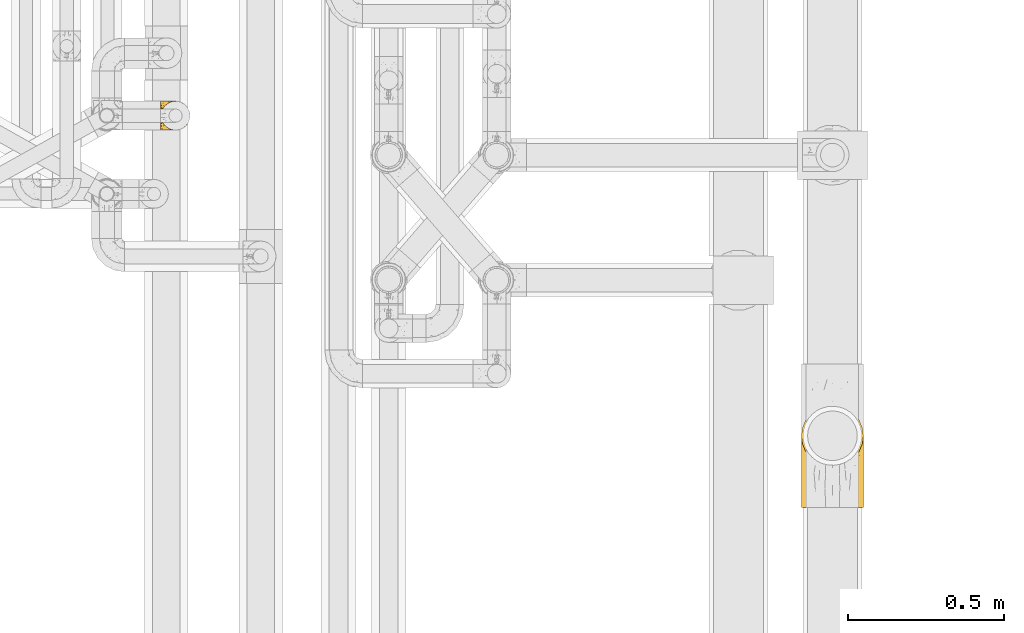
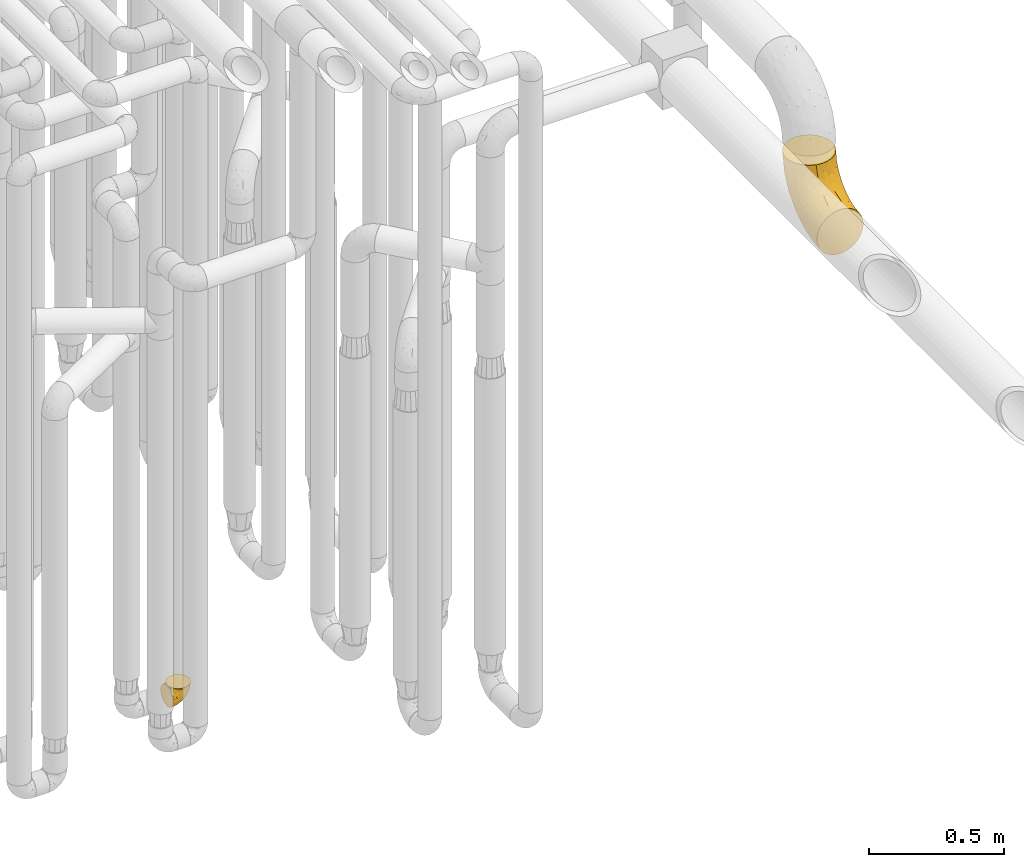
# One storey, part 198 of 827: 2 coverings.
"""IFC2X3 building model written with IfcOpenShell, lengths in millimetres."""

from ifc_helpers import new_model, entity, si_unit, converted_unit, derived_unit, direction, frame, origin, place, context, subcontext, project, spatial, faceted_brep, element, save


model = new_model("IFC2X3")

# Units and contexts
model_context = context("Model", 3, precision=0.01, world=origin(), true_north=direction((6.12303176911189e-17, 1.0)))
body_context = subcontext(model_context, "Body", "Model", "MODEL_VIEW")
ifc_project = project(units=[si_unit("LENGTHUNIT", "METRE", prefix="MILLI"), si_unit("AREAUNIT", "SQUARE_METRE"), si_unit("VOLUMEUNIT", "CUBIC_METRE"), converted_unit("PLANEANGLEUNIT", "DEGREE", entity("IfcRatioMeasure", 0.0174532925199433), si_unit("PLANEANGLEUNIT", "RADIAN"), dimensions=[0, 0, 0, 0, 0, 0, 0]), si_unit("MASSUNIT", "GRAM", prefix="KILO"), derived_unit("MASSDENSITYUNIT", [(si_unit("MASSUNIT", "GRAM", prefix="KILO"), 1), (si_unit("LENGTHUNIT", "METRE"), -3)]), derived_unit("MOMENTOFINERTIAUNIT", [(si_unit("LENGTHUNIT", "METRE"), 4)]), si_unit("TIMEUNIT", "SECOND"), si_unit("FREQUENCYUNIT", "HERTZ"), si_unit("THERMODYNAMICTEMPERATUREUNIT", "DEGREE_CELSIUS"), derived_unit("THERMALTRANSMITTANCEUNIT", [(si_unit("MASSUNIT", "GRAM", prefix="KILO"), 1), (si_unit("THERMODYNAMICTEMPERATUREUNIT", "KELVIN"), -1), (si_unit("TIMEUNIT", "SECOND"), -3)]), derived_unit("VOLUMETRICFLOWRATEUNIT", [(si_unit("LENGTHUNIT", "METRE"), 3), (si_unit("TIMEUNIT", "SECOND"), -1)]), derived_unit("MASSFLOWRATEUNIT", [(si_unit("MASSUNIT", "GRAM", prefix="KILO"), 1), (si_unit("TIMEUNIT", "SECOND"), -1)]), derived_unit("ROTATIONALFREQUENCYUNIT", [(si_unit("TIMEUNIT", "SECOND"), -1)]), si_unit("ELECTRICCURRENTUNIT", "AMPERE"), si_unit("ELECTRICVOLTAGEUNIT", "VOLT"), si_unit("POWERUNIT", "WATT"), si_unit("FORCEUNIT", "NEWTON", prefix="KILO"), si_unit("ILLUMINANCEUNIT", "LUX"), si_unit("LUMINOUSFLUXUNIT", "LUMEN"), si_unit("LUMINOUSINTENSITYUNIT", "CANDELA"), derived_unit("USERDEFINED", [(si_unit("MASSUNIT", "GRAM", prefix="KILO"), -1), (si_unit("LENGTHUNIT", "METRE"), -2), (si_unit("TIMEUNIT", "SECOND"), 3), (si_unit("LUMINOUSFLUXUNIT", "LUMEN"), 1)]), derived_unit("LINEARVELOCITYUNIT", [(si_unit("LENGTHUNIT", "METRE"), 1), (si_unit("TIMEUNIT", "SECOND"), -1)]), si_unit("PRESSUREUNIT", "PASCAL"), derived_unit("USERDEFINED", [(si_unit("LENGTHUNIT", "METRE"), -2), (si_unit("MASSUNIT", "GRAM", prefix="KILO"), 1), (si_unit("TIMEUNIT", "SECOND"), -2)]), derived_unit("LINEARFORCEUNIT", [(si_unit("MASSUNIT", "GRAM", prefix="KILO"), 1), (si_unit("LENGTHUNIT", "METRE"), 1), (si_unit("TIMEUNIT", "SECOND"), -2), (si_unit("LENGTHUNIT", "METRE"), -1)]), derived_unit("PLANARFORCEUNIT", [(si_unit("MASSUNIT", "GRAM", prefix="KILO"), 1), (si_unit("LENGTHUNIT", "METRE"), 1), (si_unit("TIMEUNIT", "SECOND"), -2), (si_unit("LENGTHUNIT", "METRE"), -2)])], contexts=[model_context])

# Site, building, storey
site_placement = place(None, origin())
site = spatial("IfcSite", under=ifc_project, at=site_placement, CompositionType="ELEMENT")
building_placement = place(site_placement, origin())
building = spatial("IfcBuilding", under=site, at=building_placement, CompositionType="ELEMENT")
storey_placement = place(building_placement, frame((0.0, 0.0, 28200.0)))
storey = spatial("IfcBuildingStorey", under=building, at=storey_placement, Name="08", CompositionType="ELEMENT", Elevation=28200.0)

# Coverings
covering_1_placement = place(storey_placement, frame((35898.45, 10558.41, 352.2)))
element("IfcCovering", 1, at=covering_1_placement, inside=storey, Name=":ADSK_", ObjectType=":ADSK_", PredefinedType="INSULATION", context=body_context, shape_type="Brep", body=[
    faceted_brep([(78.41, 11.68, 95.8), (85.72, 19.0, 95.8), (91.22, 27.76, 95.8), (94.64, 37.52, 95.8), (95.8, 47.8, 95.8), (94.64, 58.08, 95.8), (91.22, 67.85, 95.8), (85.71, 76.61, 95.8), (78.39, 83.92, 95.8), (69.63, 89.42, 95.8), (59.87, 92.84, 95.8), (49.6, 94.0, 95.8), (45.45, 93.53, 95.8), (42.38, 93.18, 95.8), (39.31, 92.84, 95.8), (34.43, 91.13, 95.8), (29.54, 89.42, 95.8), (25.16, 86.66, 95.8), (20.78, 83.91, 95.8), (17.13, 80.25, 95.8), (13.47, 76.59, 95.8), (7.97, 67.83, 95.8), (6.26, 62.95, 95.8), (4.55, 58.07, 95.8), (3.4, 47.8, 95.8), (4.55, 37.51, 95.8), (6.26, 32.63, 95.8), (7.97, 27.74, 95.8), (13.48, 18.98, 95.8), (17.14, 15.33, 95.8), (20.8, 11.67, 95.8), (25.18, 8.92, 95.8), (29.56, 6.17, 95.8), (34.44, 4.46, 95.8), (39.32, 2.75, 95.8), (42.39, 2.41, 95.8), (45.45, 2.06, 95.8), (49.6, 1.6, 95.8), (59.88, 2.75, 95.8), (69.65, 6.17, 95.8), (1.6, 47.8, 94.0), (1.6, 59.75, 92.42), (1.6, 70.9, 87.81), (1.6, 75.68, 84.13), (1.6, 80.46, 80.46), (1.6, 84.13, 75.68), (1.6, 87.81, 70.9), (1.6, 90.11, 65.32), (1.6, 92.42, 59.75), (1.6, 92.9, 56.14), (1.6, 93.17, 54.06), (1.6, 93.45, 51.97), (1.6, 94.0, 47.8), (1.6, 92.42, 35.84), (1.6, 87.81, 24.7), (1.6, 80.46, 15.13), (1.6, 70.9, 7.78), (1.6, 59.75, 3.17), (1.6, 47.8, 1.6), (1.6, 35.84, 3.17), (1.6, 24.7, 7.78), (1.6, 15.13, 15.13), (1.6, 7.78, 24.7), (1.6, 3.17, 35.84), (1.6, 1.6, 47.8), (1.6, 2.14, 51.97), (1.6, 2.69, 56.14), (1.6, 3.17, 59.75), (1.6, 5.48, 65.32), (1.6, 7.78, 70.9), (1.6, 11.46, 75.68), (1.6, 15.13, 80.46), (1.6, 19.91, 84.13), (1.6, 24.7, 87.81), (1.6, 35.84, 92.42), (36.81, 23.61, 15.84), (23.28, 31.99, 6.99), (45.8, 35.87, 14.39), (30.7, 47.8, 6.21), (21.2, 40.43, 4.26), (12.96, 47.8, 3.39), (66.19, 31.83, 31.2), (54.51, 23.37, 26.47), (17.98, 21.41, 11.44), (36.69, 3.07, 47.66), (35.54, 1.6, 61.85), (31.64, 1.6, 59.25), (27.75, 1.6, 56.65), (23.86, 1.6, 54.05), (19.96, 1.6, 51.45), (22.8, 13.45, 19.8), (42.67, 15.25, 26.22), (33.21, 8.07, 31.58), (59.45, 16.0, 38.36), (71.5, 17.34, 51.54), (62.66, 10.58, 51.6), (54.5, 5.34, 55.97), (47.57, 2.39, 62.88), (48.81, 8.36, 41.35), (74.98, 10.04, 82.24), (18.7, 2.59, 40.88), (15.75, 6.28, 29.0), (91.17, 34.28, 74.06), (85.28, 38.73, 54.53), (82.58, 27.25, 57.98), (75.78, 29.88, 43.81), (74.98, 38.6, 38.22), (67.27, 23.44, 38.33), (87.38, 25.25, 74.76), (82.04, 17.23, 76.85), (94.0, 47.8, 84.43), (77.8, 47.8, 40.43), (67.38, 47.8, 30.01), (56.2, 2.53, 78.67), (48.85, 1.6, 92.06), (48.11, 1.6, 88.32), (47.57, 1.6, 85.6), (47.03, 1.6, 82.88), (46.48, 1.6, 80.15), (45.94, 1.6, 77.43), (65.78, 5.71, 76.36), (17.24, 1.6, 50.91), (14.51, 1.6, 50.37), (11.79, 1.6, 49.82), (9.07, 1.6, 49.28), (7.2, 1.6, 48.91), (5.33, 1.6, 48.54), (91.18, 47.8, 66.69), (43.34, 1.6, 73.53), (40.74, 1.6, 69.64), (38.14, 1.6, 65.75), (72.73, 11.89, 66.13), (56.96, 47.8, 19.59), (62.23, 39.69, 24.64), (84.49, 47.8, 53.56), (43.83, 47.8, 12.9), (12.05, 13.84, 82.81), (18.95, 9.16, 81.22), (13.02, 15.79, 86.57), (8.34, 25.75, 92.75), (14.63, 16.09, 89.68), (11.09, 7.51, 72.26), (13.66, 3.99, 64.73), (20.08, 2.66, 62.45), (9.61, 3.16, 60.63), (9.48, 2.35, 56.91), (16.1, 2.23, 58.14), (3.42, 38.35, 93.7), (26.63, 6.18, 83.4), (33.72, 2.7, 75.54), (34.77, 2.93, 79.46), (6.75, 16.01, 82.28), (13.31, 9.08, 76.25), (21.11, 9.3, 84.69), (19.94, 11.68, 90.18), (8.67, 4.65, 65.12), (26.11, 3.65, 71.71), (29.3, 3.61, 75.21), (6.32, 12.8, 78.6), (39.92, 2.43, 87.27), (27.05, 6.83, 87.92), (6.04, 21.65, 86.94), (34.4, 3.7, 86.1), (2.87, 47.8, 94.52), (20.92, 3.37, 66.23), (27.43, 7.03, 91.08), (7.54, 7.87, 71.77), (18.45, 7.26, 76.21), (23.88, 3.41, 68.59), (7.77, 23.81, 89.94), (13.3, 86.5, 76.25), (11.09, 88.08, 72.26), (6.33, 82.79, 78.6), (9.07, 94.0, 49.28), (5.33, 94.0, 48.54), (14.51, 94.0, 50.37), (11.79, 94.0, 49.82), (3.42, 57.24, 93.7), (7.76, 71.76, 89.95), (47.03, 94.0, 82.88), (47.57, 94.0, 85.6), (48.85, 94.0, 92.06), (48.11, 94.0, 88.32), (14.62, 79.49, 89.68), (27.03, 88.75, 87.92), (20.08, 92.93, 62.45), (20.92, 92.22, 66.24), (27.75, 94.0, 56.65), (31.64, 94.0, 59.25), (9.61, 92.43, 60.63), (9.48, 93.24, 56.91), (8.33, 69.82, 92.76), (6.74, 79.57, 82.28), (12.04, 81.74, 82.81), (23.86, 94.0, 54.05), (19.96, 94.0, 51.45), (16.1, 93.36, 58.14), (19.93, 83.9, 90.18), (21.1, 86.28, 84.7), (39.92, 93.16, 87.25), (33.68, 92.88, 75.58), (29.28, 91.98, 75.2), (26.62, 89.41, 83.39), (26.08, 91.93, 71.7), (18.93, 86.42, 81.22), (27.87, 88.82, 90.73), (34.75, 92.66, 79.47), (6.04, 73.93, 86.94), (38.14, 94.0, 65.75), (12.79, 79.5, 86.75), (34.41, 91.89, 86.08), (45.94, 94.0, 77.43), (43.34, 94.0, 73.53), (40.74, 94.0, 69.64), (13.66, 91.6, 64.73), (17.24, 94.0, 50.91), (8.67, 90.94, 65.12), (35.54, 94.0, 61.85), (23.83, 92.16, 68.62), (18.43, 88.32, 76.22), (6.03, 86.13, 74.03), (46.48, 94.0, 80.15), (34.52, 93.2, 49.81), (21.2, 55.16, 4.26), (23.82, 82.02, 19.95), (41.32, 84.29, 30.61), (47.62, 76.94, 25.71), (52.66, 68.33, 22.43), (36.81, 71.98, 15.85), (49.75, 92.52, 60.69), (19.07, 92.9, 40.49), (45.8, 59.72, 14.39), (23.28, 63.6, 6.99), (21.35, 88.89, 29.56), (17.98, 74.18, 11.45), (82.57, 68.35, 57.98), (91.17, 61.33, 74.06), (85.27, 56.86, 54.52), (73.89, 68.62, 43.47), (66.19, 63.76, 31.2), (62.43, 72.19, 33.27), (63.53, 88.69, 64.26), (58.45, 92.19, 74.29), (67.16, 89.75, 80.41), (62.22, 55.9, 24.64), (81.54, 77.99, 73.62), (74.8, 85.21, 78.98), (75.83, 74.99, 53.69), (41.45, 90.23, 42.86), (76.72, 59.86, 41.67), (88.2, 70.75, 79.66), (71.6, 81.72, 58.41), (56.23, 86.53, 47.11), (59.44, 79.6, 38.37)], [[[0, 1, 2, 3, 4, 5, 6, 7, 8, 9, 10, 11, 12, 13, 14, 15, 16, 17, 18, 19, 20, 21, 22, 23, 24, 25, 26, 27, 28, 29, 30, 31, 32, 33, 34, 35, 36, 37, 38, 39]], [[40, 41, 42, 43, 44, 45, 46, 47, 48, 49, 50, 51, 52, 53, 54, 55, 56, 57, 58, 59, 60, 61, 62, 63, 64, 65, 66, 67, 68, 69, 70, 71, 72, 73, 74]], [[75, 76, 77]], [[78, 79, 80]], [[77, 81, 82]], [[76, 75, 83]], [[84, 85, 86, 87, 88, 89]], [[90, 91, 92]], [[76, 60, 59]], [[93, 94, 95]], [[90, 62, 61]], [[83, 61, 60]], [[96, 97, 84]], [[98, 93, 95]], [[0, 39, 99]], [[100, 84, 89]], [[62, 101, 63]], [[2, 102, 3]], [[92, 84, 100]], [[103, 102, 104]], [[103, 105, 106]], [[93, 107, 94]], [[1, 108, 2]], [[92, 101, 90]], [[108, 1, 109]], [[102, 110, 3]], [[93, 82, 107]], [[102, 108, 104]], [[111, 106, 112]], [[109, 0, 99]], [[113, 37, 114, 115, 116, 117, 118, 119]], [[120, 38, 113]], [[100, 89, 121, 122, 123, 124, 125, 126, 64]], [[127, 102, 103]], [[97, 119, 128, 129, 130, 85]], [[99, 120, 131]], [[132, 133, 77]], [[59, 80, 79]], [[1, 0, 109]], [[98, 84, 92]], [[94, 109, 131]], [[120, 39, 38]], [[93, 91, 82]], [[104, 94, 105]], [[97, 113, 119]], [[95, 120, 96]], [[83, 90, 61]], [[91, 93, 98]], [[64, 63, 100]], [[100, 63, 101]], [[77, 76, 79]], [[133, 106, 81]], [[84, 97, 85]], [[113, 96, 120]], [[113, 97, 96]], [[37, 113, 38]], [[110, 102, 127]], [[110, 4, 3]], [[103, 111, 134, 127]], [[90, 75, 91]], [[82, 81, 107]], [[91, 75, 82]], [[77, 82, 75]], [[76, 83, 60]], [[90, 83, 75]], [[105, 107, 81]], [[94, 131, 95]], [[105, 94, 107]], [[109, 94, 104]], [[120, 95, 131]], [[98, 95, 96]], [[84, 98, 96]], [[98, 92, 91]], [[106, 105, 81]], [[103, 104, 105]], [[112, 106, 133]], [[103, 106, 111]], [[112, 133, 132]], [[81, 77, 133]], [[77, 78, 135, 132]], [[120, 99, 39]], [[109, 99, 131]], [[59, 58, 80]], [[59, 79, 76]], [[90, 101, 62]], [[100, 101, 92]], [[2, 108, 102]], [[109, 104, 108]], [[78, 77, 79]], [[136, 137, 138]], [[27, 139, 140]], [[141, 142, 143]], [[144, 145, 121]], [[146, 89, 88]], [[147, 139, 25]], [[148, 149, 150]], [[136, 151, 152]], [[147, 40, 74]], [[24, 147, 25]], [[140, 153, 154]], [[33, 116, 34]], [[73, 72, 151]], [[114, 37, 36, 35, 34, 116, 115]], [[146, 155, 144]], [[156, 85, 130]], [[157, 149, 148]], [[151, 158, 152]], [[117, 33, 159]], [[29, 154, 160]], [[161, 74, 73]], [[162, 128, 119]], [[66, 65, 64, 126, 125, 124, 123, 122, 67]], [[163, 147, 24]], [[27, 140, 28]], [[149, 129, 150]], [[139, 27, 26, 25]], [[68, 144, 69]], [[129, 128, 150]], [[164, 87, 86]], [[130, 129, 149]], [[122, 145, 67]], [[154, 153, 148]], [[162, 119, 159]], [[165, 30, 160]], [[150, 160, 148]], [[128, 162, 150]], [[30, 165, 31]], [[145, 144, 68]], [[89, 146, 144]], [[87, 164, 143]], [[166, 155, 142]], [[88, 87, 143]], [[162, 160, 150]], [[160, 30, 29]], [[154, 29, 28]], [[140, 154, 28]], [[160, 154, 148]], [[140, 137, 153]], [[157, 148, 153]], [[156, 130, 157]], [[153, 137, 157]], [[157, 137, 156]], [[167, 137, 136]], [[168, 85, 156]], [[152, 168, 167]], [[167, 168, 156]], [[164, 152, 141]], [[71, 158, 72]], [[152, 167, 136]], [[88, 142, 146]], [[144, 155, 69]], [[146, 142, 155]], [[70, 166, 71]], [[142, 141, 166]], [[70, 69, 155]], [[141, 158, 71]], [[161, 73, 151]], [[138, 137, 140]], [[161, 136, 169]], [[136, 161, 151]], [[74, 161, 169]], [[152, 158, 141]], [[151, 72, 158]], [[168, 152, 164]], [[137, 167, 156]], [[164, 86, 168]], [[85, 168, 86]], [[116, 33, 117]], [[130, 149, 157]], [[67, 145, 68]], [[121, 89, 144]], [[145, 122, 121]], [[40, 147, 163]], [[169, 147, 74]], [[159, 33, 32]], [[162, 159, 32]], [[159, 119, 118, 117]], [[139, 147, 169]], [[139, 169, 138]], [[162, 32, 31]], [[141, 143, 164]], [[88, 143, 142]], [[71, 166, 141]], [[155, 166, 70]], [[139, 138, 140]], [[169, 136, 138]], [[160, 162, 165]], [[162, 31, 165]], [[170, 171, 172]], [[173, 174, 52, 51, 50, 49, 48, 175, 176]], [[177, 178, 41]], [[179, 15, 180]], [[12, 11, 181, 182, 180, 14, 13]], [[183, 21, 20]], [[19, 18, 184]], [[185, 186, 187]], [[186, 188, 187]], [[43, 172, 44]], [[189, 190, 47]], [[23, 22, 21, 191]], [[170, 192, 193]], [[40, 163, 177]], [[194, 195, 196]], [[24, 23, 177]], [[197, 198, 183]], [[199, 15, 179]], [[47, 46, 189]], [[200, 201, 202]], [[201, 203, 204]], [[205, 206, 184]], [[207, 41, 178]], [[16, 15, 199]], [[14, 180, 15]], [[202, 201, 198]], [[208, 201, 200]], [[163, 24, 177]], [[48, 47, 190]], [[196, 195, 189]], [[197, 184, 202]], [[204, 193, 209]], [[210, 211, 212]], [[206, 212, 213]], [[205, 17, 210]], [[184, 206, 202]], [[210, 212, 206]], [[185, 194, 214]], [[189, 215, 190]], [[216, 45, 214]], [[186, 171, 170]], [[189, 216, 196]], [[197, 20, 19]], [[194, 185, 187]], [[197, 183, 20]], [[184, 197, 19]], [[197, 202, 198]], [[206, 200, 202]], [[204, 183, 198]], [[201, 208, 203]], [[203, 208, 217]], [[204, 198, 201]], [[217, 188, 218]], [[193, 219, 170]], [[171, 186, 185]], [[170, 218, 186]], [[170, 219, 218]], [[42, 207, 192]], [[171, 220, 172]], [[216, 189, 46]], [[214, 194, 196]], [[44, 220, 45]], [[214, 196, 216]], [[216, 46, 45]], [[214, 45, 220]], [[192, 43, 42]], [[204, 203, 219]], [[207, 193, 192]], [[209, 193, 178]], [[41, 207, 42]], [[193, 207, 178]], [[43, 192, 172]], [[170, 172, 192]], [[204, 219, 193]], [[219, 203, 218]], [[217, 218, 203]], [[188, 186, 218]], [[206, 213, 200]], [[208, 200, 213]], [[199, 210, 16]], [[215, 189, 195]], [[215, 175, 190]], [[175, 48, 190]], [[199, 179, 221, 211]], [[210, 199, 211]], [[23, 191, 177]], [[40, 177, 41]], [[178, 177, 191]], [[21, 183, 191]], [[209, 191, 183]], [[205, 18, 17]], [[17, 16, 210]], [[171, 185, 214]], [[172, 220, 44]], [[214, 220, 171]], [[191, 209, 178]], [[204, 209, 183]], [[206, 205, 210]], [[18, 205, 184]], [[222, 195, 194, 187, 188, 217]], [[57, 223, 80]], [[224, 225, 226]], [[226, 227, 228]], [[229, 217, 208, 213, 212, 211]], [[230, 52, 174, 173, 176, 175, 215, 195]], [[231, 232, 228]], [[231, 78, 223]], [[223, 57, 232]], [[224, 233, 225]], [[233, 54, 53]], [[234, 232, 56]], [[56, 55, 234]], [[234, 224, 228]], [[235, 236, 237]], [[224, 55, 54]], [[238, 239, 240]], [[52, 230, 53]], [[241, 242, 243]], [[227, 244, 231]], [[11, 10, 242]], [[236, 6, 5]], [[7, 245, 8]], [[8, 246, 9]], [[238, 247, 235]], [[222, 229, 248]], [[242, 211, 221, 179, 180, 182, 181, 11]], [[233, 53, 230]], [[111, 112, 249]], [[250, 6, 236]], [[246, 251, 241]], [[6, 250, 7]], [[127, 236, 110]], [[248, 229, 252]], [[246, 8, 245]], [[235, 245, 250]], [[236, 5, 110]], [[235, 249, 238]], [[237, 236, 127]], [[243, 9, 246]], [[252, 229, 241]], [[56, 232, 57]], [[222, 230, 195]], [[225, 248, 252]], [[248, 233, 230]], [[54, 233, 224]], [[231, 228, 227]], [[244, 132, 231]], [[248, 225, 233]], [[226, 225, 253]], [[235, 250, 236]], [[245, 7, 250]], [[251, 246, 245]], [[243, 246, 241]], [[247, 245, 235]], [[252, 251, 253]], [[229, 222, 217]], [[230, 222, 248]], [[5, 4, 110]], [[237, 127, 134, 111]], [[238, 249, 239]], [[224, 234, 55]], [[232, 234, 228]], [[242, 241, 229]], [[10, 9, 243]], [[211, 242, 229]], [[10, 243, 242]], [[80, 223, 78]], [[80, 58, 57]], [[231, 223, 232]], [[227, 240, 239]], [[224, 226, 228]], [[240, 226, 253]], [[227, 239, 244]], [[226, 240, 227]], [[251, 247, 253]], [[240, 253, 247]], [[249, 235, 237]], [[237, 111, 249]], [[112, 132, 244]], [[112, 244, 249]], [[78, 231, 132, 135]], [[249, 244, 239]], [[247, 238, 240]], [[245, 247, 251]], [[251, 252, 241]], [[225, 252, 253]]]),
])
covering_2_placement = place(storey_placement, frame((37947.55, 9352.12, 2399.25)))
element("IfcCovering", 2, at=covering_2_placement, inside=storey, Name=":ADSK_", ObjectType=":ADSK_", PredefinedType="INSULATION", context=body_context, shape_type="Brep", body=[
    faceted_brep([(1.6, 1.6, 100.75), (3.1, 1.6, 83.53), (7.58, 1.6, 66.83), (14.88, 1.6, 51.17), (24.8, 1.6, 37.01), (37.02, 1.6, 24.79), (51.18, 1.6, 14.87), (66.84, 1.6, 7.57), (83.54, 1.6, 3.1), (100.75, 1.6, 1.6), (117.96, 1.6, 3.1), (134.66, 1.6, 7.58), (150.32, 1.6, 14.88), (164.48, 1.6, 24.8), (176.7, 1.6, 37.02), (186.62, 1.6, 51.18), (193.92, 1.6, 66.84), (198.39, 1.6, 83.54), (199.9, 1.6, 100.75), (198.39, 1.6, 117.96), (193.91, 1.6, 134.66), (186.61, 1.6, 150.32), (176.69, 1.6, 164.48), (164.47, 1.6, 176.7), (150.31, 1.6, 186.62), (134.65, 1.6, 193.92), (117.95, 1.6, 198.39), (100.75, 1.6, 199.9), (83.53, 1.6, 198.39), (66.83, 1.6, 193.91), (51.17, 1.6, 186.61), (37.01, 1.6, 176.69), (24.79, 1.6, 164.47), (14.87, 1.6, 150.31), (7.57, 1.6, 134.65), (3.1, 1.6, 117.95), (126.41, 134.82, 329.75), (150.32, 144.73, 329.75), (170.85, 160.49, 329.75), (186.61, 181.02, 329.75), (196.52, 204.93, 329.75), (199.9, 230.6, 329.75), (196.52, 256.26, 329.75), (186.61, 280.17, 329.75), (170.85, 300.7, 329.75), (150.32, 316.46, 329.75), (126.41, 326.37, 329.75), (100.75, 329.75, 329.75), (75.08, 326.37, 329.75), (51.17, 316.46, 329.75), (30.64, 300.7, 329.75), (14.88, 280.17, 329.75), (4.97, 256.26, 329.75), (1.6, 230.6, 329.75), (4.97, 204.93, 329.75), (14.88, 181.02, 329.75), (30.64, 160.49, 329.75), (51.17, 144.73, 329.75), (75.08, 134.82, 329.75), (100.75, 131.45, 329.75), (74.55, 312.99, 238.01), (100.75, 323.44, 265.73), (100.75, 304.77, 204.17), (14.13, 60.87, 58.91), (68.66, 205.84, 79.76), (46.71, 243.27, 132.21), (67.05, 253.87, 129.24), (100.75, 233.63, 97.71), (3.51, 204.27, 186.17), (1.6, 144.37, 150.71), (1.6, 180.63, 186.97), (56.83, 283.61, 183.03), (77.71, 288.26, 175.7), (6.57, 69.96, 78.89), (26.42, 274.76, 219.35), (32.44, 253.08, 164.59), (19.41, 230.82, 159.21), (100.75, 274.44, 147.43), (43.94, 188.83, 82.35), (48.78, 131.44, 44.46), (30.05, 142.07, 66.34), (100.75, 183.91, 56.9), (61.14, 74.6, 18.29), (67.31, 132.68, 35.26), (81.57, 94.72, 17.04), (23.93, 289.09, 280.46), (43.17, 302.19, 255.09), (4.14, 235.0, 236.53), (100.75, 65.61, 7.9), (100.75, 127.17, 26.57), (12.37, 260.27, 239.55), (14.92, 119.28, 77.16), (58.7, 315.28, 272.89), (9.37, 223.14, 179.84), (14.55, 183.59, 119.6), (29.48, 212.26, 119.08), (5.41, 143.44, 116.35), (1.6, 207.92, 230.39), (1.6, 100.95, 123.42), (33.48, 74.78, 36.91), (40.31, 281.73, 202.68), (1.6, 224.85, 278.79), (1.6, 52.55, 106.49), (34.24, 148.84, 279.85), (20.76, 142.09, 233.31), (36.98, 131.06, 248.07), (5.53, 197.3, 282.45), (100.75, 35.2, 204.32), (71.92, 38.85, 200.89), (10.32, 155.69, 221.48), (8.28, 138.22, 193.12), (17.31, 126.11, 206.15), (3.87, 164.53, 200.63), (4.45, 183.55, 234.54), (7.06, 47.01, 138.52), (29.72, 114.61, 216.73), (58.59, 90.01, 222.16), (62.2, 110.04, 244.97), (45.23, 109.35, 229.98), (38.13, 52.51, 186.39), (100.75, 114.05, 264.82), (100.75, 127.02, 296.14), (76.92, 123.55, 277.3), (18.05, 172.33, 294.68), (53.25, 132.14, 273.95), (9.87, 109.3, 174.02), (23.61, 86.6, 186.35), (100.75, 66.52, 217.29), (60.22, 137.9, 305.12), (37.04, 81.01, 198.94), (82.48, 105.71, 249.34), (100.75, 93.41, 237.93), (54.15, 32.55, 191.69), (3.94, 109.37, 152.36), (11.68, 76.79, 160.25), (76.92, 82.88, 224.79), (51.95, 64.13, 201.49), (25.4, 44.65, 170.92), (15.89, 33.7, 154.96), (3.04, 145.76, 174.17), (3.65, 81.0, 136.48), (13.74, 166.23, 253.47), (164.51, 131.06, 248.07), (167.26, 148.84, 279.84), (148.24, 132.14, 273.95), (195.96, 197.3, 282.45), (199.9, 207.92, 230.39), (199.9, 224.85, 278.79), (119.01, 105.71, 249.34), (187.75, 166.23, 253.46), (183.44, 172.33, 294.68), (124.56, 82.88, 224.79), (180.73, 142.08, 233.3), (191.16, 155.68, 221.48), (198.13, 31.12, 121.48), (124.56, 123.55, 277.3), (129.56, 38.84, 200.89), (199.9, 100.95, 123.42), (194.43, 47.02, 138.53), (199.9, 52.55, 106.49), (153.39, 143.28, 299.03), (139.28, 110.04, 244.97), (142.9, 90.01, 222.16), (156.25, 109.36, 230.0), (177.87, 86.6, 186.36), (191.63, 109.32, 174.01), (184.18, 126.08, 206.14), (176.09, 44.66, 170.94), (189.8, 76.81, 160.27), (149.53, 64.13, 201.5), (199.9, 180.63, 186.97), (197.62, 164.52, 200.62), (198.44, 145.75, 174.17), (163.35, 52.5, 186.4), (164.44, 81.01, 198.95), (197.04, 183.55, 234.52), (147.32, 32.55, 191.7), (186.65, 44.0, 155.33), (196.14, 79.09, 143.22), (197.55, 109.36, 152.35), (193.21, 138.22, 193.12), (171.76, 114.6, 216.74), (199.9, 144.37, 150.71), (197.35, 235.0, 236.53), (197.98, 204.27, 186.17), (192.12, 223.14, 179.84), (126.94, 312.99, 238.01), (194.93, 69.96, 78.9), (186.57, 119.29, 77.18), (186.94, 183.6, 119.62), (196.08, 143.44, 116.35), (171.45, 142.06, 66.35), (134.44, 253.88, 129.25), (189.12, 260.27, 239.55), (143.52, 304.98, 232.94), (158.32, 302.19, 255.09), (144.66, 283.61, 183.03), (177.56, 289.09, 280.45), (175.07, 274.76, 219.35), (132.83, 205.84, 79.76), (134.18, 132.69, 35.26), (172.02, 212.26, 119.08), (157.56, 188.81, 82.34), (123.78, 288.27, 175.7), (161.98, 271.11, 182.77), (140.37, 74.6, 18.3), (154.78, 243.26, 132.19), (174.61, 247.35, 166.31), (168.02, 74.77, 36.91), (187.37, 60.87, 58.92), (119.93, 94.72, 17.04), (152.72, 131.42, 44.46)], [[[0, 1, 2, 3, 4, 5, 6, 7, 8, 9, 10, 11, 12, 13, 14, 15, 16, 17, 18, 19, 20, 21, 22, 23, 24, 25, 26, 27, 28, 29, 30, 31, 32, 33, 34, 35]], [[36, 37, 38, 39, 40, 41, 42, 43, 44, 45, 46, 47, 48, 49, 50, 51, 52, 53, 54, 55, 56, 57, 58, 59]], [[60, 61, 62]], [[61, 48, 47]], [[63, 4, 3]], [[64, 65, 66]], [[64, 66, 67]], [[68, 69, 70]], [[71, 72, 66]], [[73, 2, 1]], [[74, 75, 76]], [[77, 72, 62]], [[78, 79, 80]], [[64, 67, 81]], [[82, 83, 84]], [[51, 50, 85]], [[86, 50, 49]], [[53, 52, 87]], [[74, 85, 86]], [[88, 84, 89]], [[74, 76, 90]], [[73, 91, 63]], [[92, 48, 60]], [[93, 68, 87]], [[94, 95, 80]], [[94, 91, 96]], [[87, 68, 97]], [[96, 98, 69]], [[82, 99, 79]], [[99, 63, 80]], [[87, 90, 93]], [[78, 65, 64]], [[84, 8, 7]], [[99, 82, 5]], [[52, 90, 87]], [[82, 84, 7]], [[92, 86, 49]], [[5, 82, 6]], [[74, 100, 75]], [[88, 9, 8]], [[87, 97, 101]], [[99, 5, 4]], [[98, 96, 73]], [[98, 73, 102]], [[6, 82, 7]], [[0, 102, 1]], [[53, 87, 101]], [[84, 83, 89]], [[71, 86, 92]], [[80, 79, 99]], [[102, 73, 1]], [[96, 69, 68]], [[96, 91, 73]], [[73, 63, 2]], [[63, 99, 4]], [[52, 51, 90]], [[48, 61, 60]], [[83, 81, 89]], [[85, 90, 51]], [[65, 75, 100]], [[8, 84, 88]], [[82, 79, 83]], [[94, 80, 91]], [[78, 80, 95]], [[79, 64, 83]], [[81, 83, 64]], [[65, 78, 95]], [[64, 79, 78]], [[75, 65, 95]], [[65, 71, 66]], [[72, 71, 60]], [[67, 66, 77]], [[62, 72, 60]], [[77, 66, 72]], [[96, 93, 94]], [[76, 94, 93]], [[96, 68, 93]], [[97, 68, 70]], [[63, 91, 80]], [[2, 63, 3]], [[76, 75, 95]], [[74, 86, 100]], [[94, 76, 95]], [[76, 93, 90]], [[86, 71, 100]], [[65, 100, 71]], [[86, 85, 50]], [[90, 85, 74]], [[48, 92, 49]], [[71, 92, 60]], [[103, 104, 105]], [[54, 53, 101]], [[54, 101, 106]], [[28, 107, 108]], [[109, 110, 111]], [[70, 112, 113]], [[106, 97, 113]], [[102, 34, 114]], [[103, 57, 56]], [[104, 115, 105]], [[116, 117, 118]], [[31, 30, 119]], [[120, 121, 122]], [[55, 123, 56]], [[124, 117, 122]], [[125, 126, 111]], [[127, 108, 107]], [[124, 128, 103]], [[105, 117, 124]], [[121, 59, 58]], [[119, 129, 126]], [[117, 130, 122]], [[131, 120, 130]], [[119, 30, 132]], [[133, 134, 125]], [[108, 135, 136]], [[32, 137, 138]], [[58, 57, 128]], [[114, 34, 33]], [[114, 138, 134]], [[133, 125, 139]], [[0, 35, 102]], [[134, 133, 140]], [[114, 33, 138]], [[106, 55, 54]], [[35, 34, 102]], [[122, 130, 120]], [[121, 58, 122]], [[29, 28, 108]], [[108, 127, 135]], [[27, 107, 28]], [[117, 105, 118]], [[137, 32, 31]], [[127, 131, 135]], [[110, 112, 139]], [[136, 132, 108]], [[56, 123, 103]], [[137, 126, 134]], [[132, 29, 108]], [[131, 130, 135]], [[123, 106, 141]], [[114, 140, 102]], [[135, 130, 117]], [[97, 106, 101]], [[126, 137, 119]], [[126, 115, 111]], [[122, 58, 128]], [[105, 124, 103]], [[104, 103, 141]], [[105, 115, 118]], [[109, 104, 141]], [[111, 115, 104]], [[106, 123, 55]], [[103, 123, 141]], [[129, 118, 115]], [[117, 116, 135]], [[129, 116, 118]], [[136, 135, 116]], [[113, 109, 141]], [[112, 110, 109]], [[106, 113, 141]], [[70, 113, 97]], [[113, 112, 109]], [[139, 70, 69]], [[70, 139, 112]], [[139, 69, 133]], [[69, 98, 133]], [[140, 133, 98]], [[109, 111, 104]], [[111, 110, 125]], [[119, 132, 136]], [[29, 132, 30]], [[119, 136, 129]], [[31, 119, 137]], [[129, 136, 116]], [[115, 126, 129]], [[126, 125, 134]], [[139, 125, 110]], [[32, 138, 33]], [[134, 138, 137]], [[103, 128, 57]], [[122, 128, 124]], [[102, 140, 98]], [[134, 140, 114]], [[142, 143, 144]], [[145, 146, 147]], [[120, 131, 148]], [[149, 150, 143]], [[127, 151, 131]], [[152, 153, 149]], [[59, 121, 36]], [[19, 154, 20]], [[120, 148, 155]], [[156, 151, 127]], [[157, 158, 159]], [[36, 144, 160]], [[161, 162, 163]], [[164, 165, 166]], [[39, 145, 40]], [[41, 40, 147]], [[164, 167, 168]], [[150, 39, 38]], [[156, 169, 151]], [[40, 145, 147]], [[36, 155, 144]], [[38, 37, 160]], [[170, 171, 172]], [[120, 155, 121]], [[151, 161, 148]], [[173, 174, 169]], [[26, 25, 156]], [[145, 149, 175]], [[150, 145, 39]], [[26, 107, 27]], [[25, 24, 176]], [[177, 22, 21]], [[22, 167, 23]], [[175, 149, 153]], [[164, 174, 173]], [[167, 173, 23]], [[156, 127, 107]], [[177, 158, 178]], [[157, 179, 178]], [[165, 172, 180]], [[21, 20, 158]], [[181, 142, 163]], [[177, 168, 167]], [[152, 149, 143]], [[19, 18, 159]], [[173, 169, 176]], [[107, 26, 156]], [[19, 159, 154]], [[143, 142, 152]], [[172, 179, 182]], [[36, 121, 155]], [[169, 156, 176]], [[164, 168, 165]], [[144, 155, 161]], [[159, 158, 154]], [[158, 20, 154]], [[151, 148, 131]], [[155, 148, 161]], [[163, 142, 144]], [[160, 144, 143]], [[163, 144, 161]], [[142, 181, 152]], [[181, 166, 152]], [[152, 166, 153]], [[143, 150, 38]], [[145, 150, 149]], [[162, 161, 151]], [[163, 162, 174]], [[151, 169, 162]], [[174, 162, 169]], [[180, 171, 153]], [[175, 170, 146]], [[175, 153, 171]], [[145, 175, 146]], [[172, 171, 180]], [[175, 171, 170]], [[179, 165, 168]], [[170, 172, 182]], [[178, 179, 168]], [[157, 182, 179]], [[164, 166, 181]], [[153, 166, 180]], [[25, 176, 156]], [[24, 23, 173]], [[173, 176, 24]], [[164, 173, 167]], [[164, 181, 174]], [[163, 174, 181]], [[172, 165, 179]], [[165, 180, 166]], [[22, 177, 167]], [[21, 158, 177]], [[38, 160, 143]], [[36, 160, 37]], [[177, 178, 168]], [[157, 178, 158]], [[183, 184, 185]], [[45, 186, 46]], [[61, 46, 186]], [[183, 41, 147]], [[146, 170, 184]], [[62, 61, 186]], [[187, 157, 159]], [[188, 189, 190]], [[188, 191, 189]], [[182, 190, 184]], [[192, 67, 77]], [[193, 183, 185]], [[194, 45, 195]], [[194, 195, 196]], [[61, 47, 46]], [[42, 193, 43]], [[44, 43, 197]], [[197, 193, 198]], [[81, 199, 200]], [[201, 191, 202]], [[44, 197, 195]], [[196, 192, 203]], [[17, 187, 159]], [[62, 186, 203]], [[183, 193, 42]], [[190, 185, 184]], [[190, 182, 157]], [[204, 195, 198]], [[205, 12, 11]], [[206, 204, 207]], [[159, 18, 17]], [[16, 187, 17]], [[14, 208, 209]], [[41, 183, 42]], [[208, 14, 13]], [[44, 195, 45]], [[185, 207, 193]], [[15, 209, 16]], [[188, 190, 187]], [[205, 210, 200]], [[81, 67, 199]], [[208, 13, 205]], [[196, 206, 192]], [[88, 89, 210]], [[191, 188, 209]], [[205, 13, 12]], [[210, 10, 88]], [[11, 10, 210]], [[9, 88, 10]], [[191, 208, 211]], [[191, 209, 208]], [[208, 205, 211]], [[200, 211, 205]], [[146, 183, 147]], [[207, 201, 206]], [[188, 187, 209]], [[187, 190, 157]], [[202, 206, 201]], [[89, 81, 200]], [[210, 205, 11]], [[202, 191, 211]], [[189, 191, 201]], [[200, 210, 89]], [[199, 211, 200]], [[211, 199, 202]], [[199, 192, 206]], [[199, 206, 202]], [[204, 206, 196]], [[67, 192, 199]], [[203, 186, 194]], [[192, 77, 203]], [[62, 203, 77]], [[207, 189, 201]], [[185, 190, 189]], [[146, 184, 183]], [[184, 170, 182]], [[16, 209, 187]], [[209, 15, 14]], [[195, 204, 196]], [[204, 198, 207]], [[193, 207, 198]], [[189, 207, 185]], [[193, 197, 43]], [[195, 197, 198]], [[203, 194, 196]], [[45, 194, 186]]]),
])

save(model, "model.ifc")
